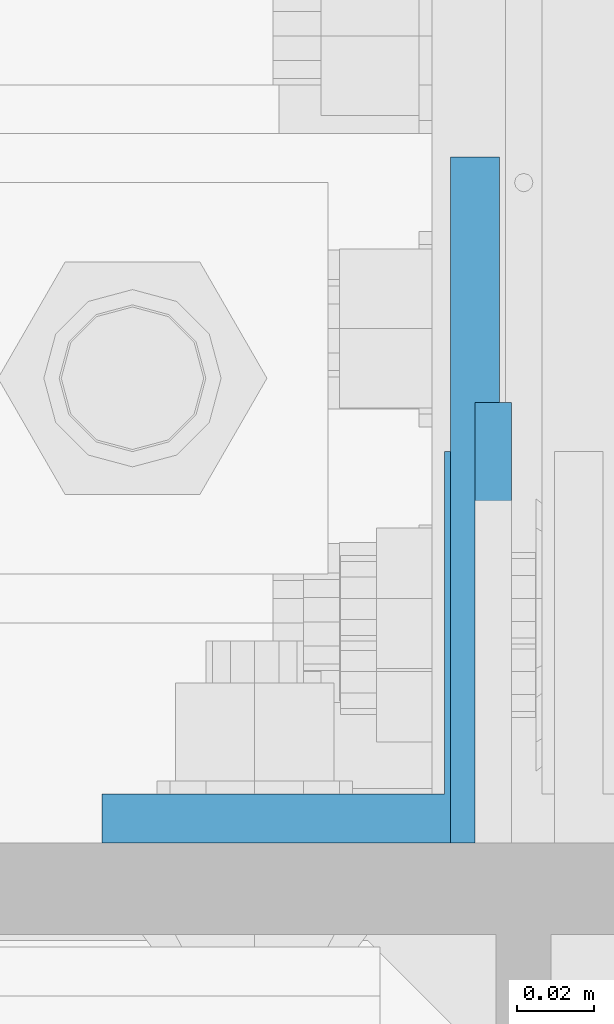
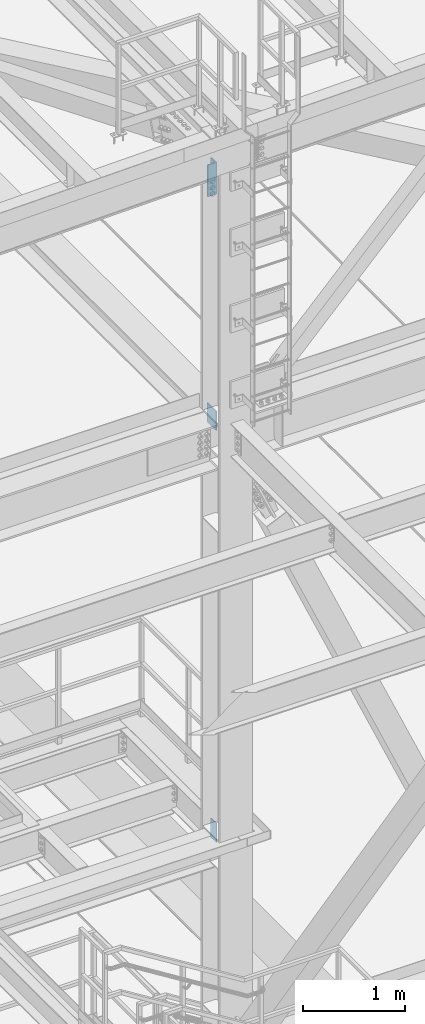
# One storey, part 1491 of 3843: 3 columns, 2 elements without a shape of their own.
"""IFC2X3 building model written with IfcOpenShell, lengths in millimetres."""

from ifc_helpers import new_model, si_unit, frame, origin_with_axes, place, context, subcontext, project, spatial, faceted_brep, material, type_object, element, aggregate, save


model = new_model("IFC2X3")

# Units and contexts
model_context = context("Model", 3, precision=1e-05, world=origin_with_axes())
body_context = subcontext(model_context, "Body", "Model", "MODEL_VIEW")
ifc_project = project(units=[si_unit("LENGTHUNIT", "METRE", prefix="MILLI"), si_unit("AREAUNIT", "SQUARE_METRE"), si_unit("VOLUMEUNIT", "CUBIC_METRE"), si_unit("MASSUNIT", "GRAM", prefix="KILO"), si_unit("TIMEUNIT", "SECOND"), si_unit("PLANEANGLEUNIT", "RADIAN"), si_unit("SOLIDANGLEUNIT", "STERADIAN"), si_unit("THERMODYNAMICTEMPERATUREUNIT", "DEGREE_CELSIUS"), si_unit("LUMINOUSINTENSITYUNIT", "LUMEN")], contexts=[model_context])

# Site, building, storey
site_placement = place(None, origin_with_axes())
site = spatial("IfcSite", under=ifc_project, at=site_placement, CompositionType="ELEMENT")
building_placement = place(site_placement, origin_with_axes())
building = spatial("IfcBuilding", under=site, at=building_placement, Name="Undefined", CompositionType="ELEMENT")
storey_placement = place(building_placement, origin_with_axes())
storey = spatial("IfcBuildingStorey", under=building, at=storey_placement, Name="Undefined", CompositionType="ELEMENT", Elevation=0.0)

# Assembly, column
assembly_1_placement = place(storey_placement, origin_with_axes())
assembly_1 = element("IfcElementAssembly", 1, at=assembly_1_placement, inside=storey, Name="COLUMN", AssemblyPlace="NOTDEFINED", PredefinedType="RIGID_FRAME")
ifc_material = material(Name="STEEL/A572-50")
column_type_1 = type_object("IfcColumnType", PredefinedType="NOTDEFINED")
column_1_placement = place(assembly_1_placement, frame((55918.0999999999, 25889.0835000024, 42130.93690066), z_axis=(0.0, -1.0, 0.0), x_axis=(0.0, 0.0, 1.0)))
column_1 = element("IfcColumn", 2, at=column_1_placement, type_object=column_type_1, material=ifc_material, Name="PLATE", context=body_context, shape_type="Brep", body=[
    faceted_brep([(0.0, 6.34999999999854, -89.033500000005), (0.0, 6.34999999999854, 89.033500000005), (228.599999999999, 6.34999999999854, 89.033500000005), (228.599999999999, 6.34999999999854, -89.033500000005), (0.0, -6.34999999999854, 89.033500000005), (228.599999999999, -6.34999999999854, 89.033500000005), (0.0, -6.34999999999854, -89.033500000005), (228.599999999999, -6.34999999999854, -89.033500000005)], [[[0, 1, 2, 3]], [[1, 4, 5, 2]], [[4, 6, 7, 5]], [[6, 0, 3, 7]], [[5, 7, 3, 2]], [[6, 4, 1, 0]]]),
])

assembly_2_placement = place(storey_placement, origin_with_axes())
assembly_2 = element("IfcElementAssembly", 3, at=assembly_2_placement, inside=storey, Name="PLATE", AssemblyPlace="NOTDEFINED", PredefinedType="RIGID_FRAME")
column_type_2 = type_object("IfcColumnType", Name="L4X4X1/2", PredefinedType="NOTDEFINED")
column_2_placement = place(assembly_2_placement, frame((55872.0625, 25850.8500000028, 44971.9660239119), z_axis=(0.0, 1.0, 0.0), x_axis=(0.0, 0.0, 1.0)))
column_2 = element("IfcColumn", 4, at=column_2_placement, type_object=column_type_2, material=ifc_material, Name="ANGLE", ObjectType="L4X4X1/2", context=body_context, shape_type="Brep", body=[
    faceted_brep([(0.0, 50.8000000000029, -50.8000000000029), (0.0, 50.8000000000029, 50.8000000000029), (381.0, 50.8000000000029, 50.8000000000029), (381.0, 50.8000000000029, -50.8000000000029), (0.0, 38.0999999999985, 50.8000000000029), (381.0, 38.0999999999985, 50.8000000000029), (0.0, 38.0999999999985, -38.0999999999985), (381.0, 38.0999999999985, -38.1000000000058), (0.0, -50.8000000000029, -38.1000000000058), (381.0, -50.8000000000029, -38.1000000000058), (0.0, -50.8000000000029, -50.8000000000029), (381.0, -50.8000000000029, -50.8000000000029)], [[[0, 1, 2, 3]], [[1, 4, 5, 2]], [[4, 6, 7, 5]], [[6, 8, 9, 7]], [[8, 10, 11, 9]], [[10, 0, 3, 11]], [[5, 7, 9, 11, 3, 2]], [[10, 8, 6, 4, 1, 0]]]),
])
aggregate(assembly_2, [column_2])

# Column
column_type_3 = type_object("IfcColumnType", PredefinedType="NOTDEFINED")
column_3_placement = place(assembly_1_placement, frame((55922.8625, 25857.2, 37176.0749999999), z_axis=(0.0, -1.0, 0.0), x_axis=(0.0, 0.0, 1.0)))
column_3 = element("IfcColumn", 5, at=column_3_placement, type_object=column_type_3, material=ifc_material, Name="PLATE", context=body_context, shape_type="Brep", body=[
    faceted_brep([(0.0, 4.76249999999709, -57.1500000000015), (0.0, 4.76249999999709, 57.1500000000015), (228.600000000006, 4.76249999999709, 57.1500000000015), (228.600000000006, 4.76249999999709, -57.1500000000015), (0.0, -4.76249999999709, 57.1500000000015), (228.600000000006, -4.76249999999709, 57.1500000000015), (0.0, -4.76249999999709, -57.1500000000015), (228.600000000006, -4.76249999999709, -57.1500000000015)], [[[0, 1, 2, 3]], [[1, 4, 5, 2]], [[4, 6, 7, 5]], [[6, 0, 3, 7]], [[5, 7, 3, 2]], [[6, 4, 1, 0]]]),
])

aggregate(assembly_1, [column_1, column_3])

save(model, "model.ifc")
